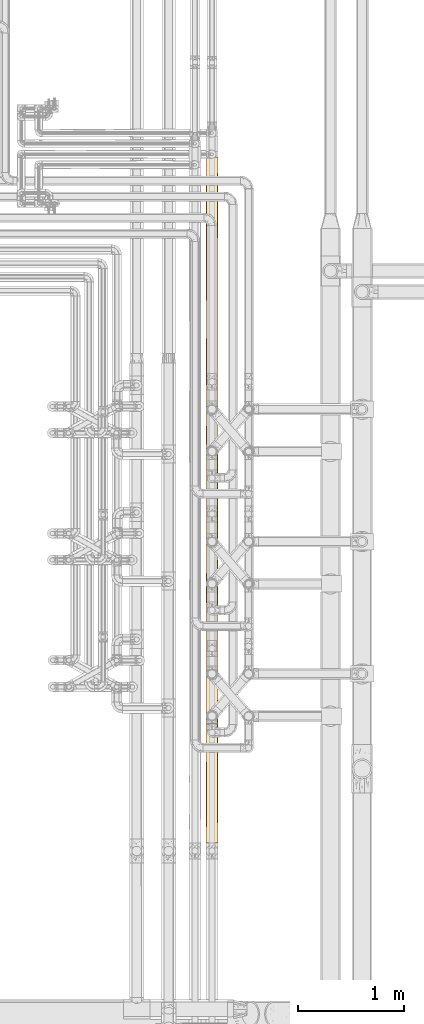
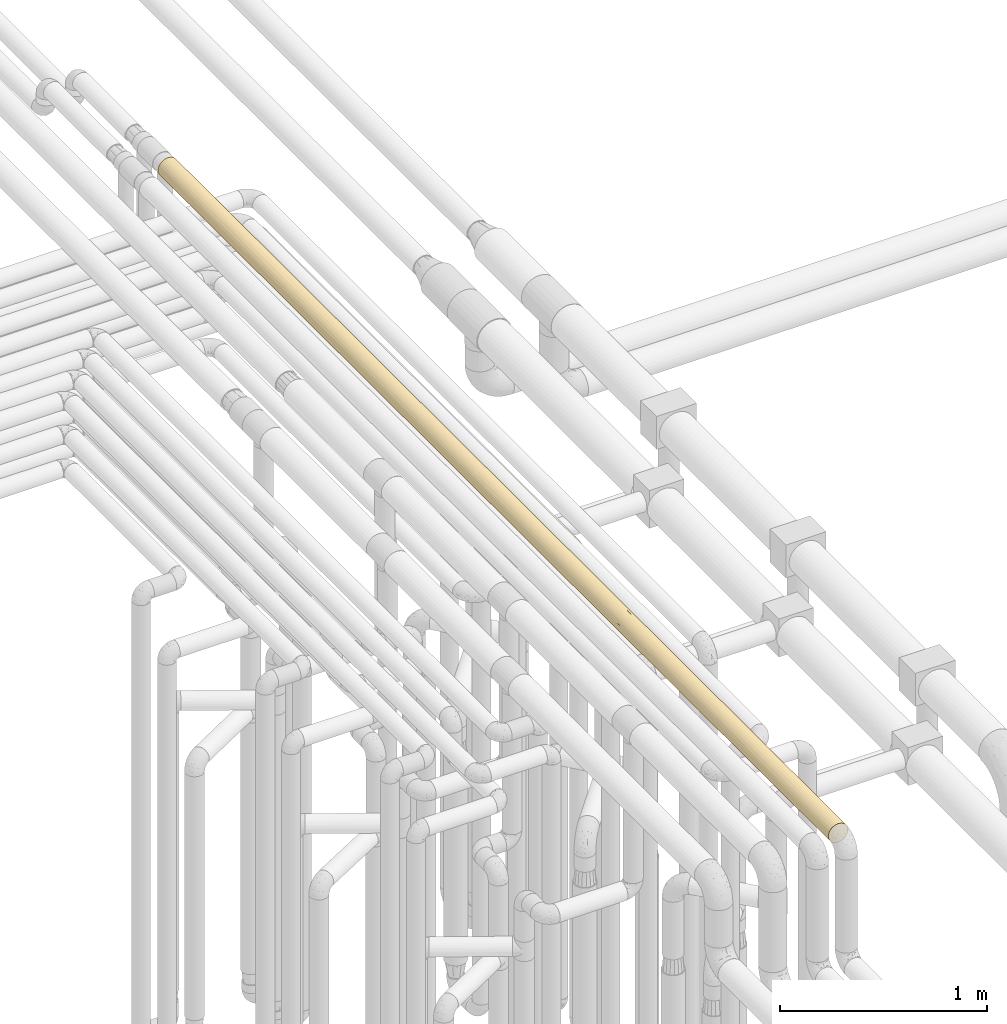
# One storey, part 37 of 827: 1 covering.
"""IFC2X3 building model written with IfcOpenShell, lengths in millimetres."""

from ifc_helpers import new_model, entity, si_unit, converted_unit, derived_unit, direction, frame, origin, place, context, subcontext, project, spatial, faceted_brep, element, save


model = new_model("IFC2X3")

# Units and contexts
model_context = context("Model", 3, precision=0.01, world=origin(), true_north=direction((6.12303176911189e-17, 1.0)))
body_context = subcontext(model_context, "Body", "Model", "MODEL_VIEW")
ifc_project = project(units=[si_unit("LENGTHUNIT", "METRE", prefix="MILLI"), si_unit("AREAUNIT", "SQUARE_METRE"), si_unit("VOLUMEUNIT", "CUBIC_METRE"), converted_unit("PLANEANGLEUNIT", "DEGREE", entity("IfcRatioMeasure", 0.0174532925199433), si_unit("PLANEANGLEUNIT", "RADIAN"), dimensions=[0, 0, 0, 0, 0, 0, 0]), si_unit("MASSUNIT", "GRAM", prefix="KILO"), derived_unit("MASSDENSITYUNIT", [(si_unit("MASSUNIT", "GRAM", prefix="KILO"), 1), (si_unit("LENGTHUNIT", "METRE"), -3)]), derived_unit("MOMENTOFINERTIAUNIT", [(si_unit("LENGTHUNIT", "METRE"), 4)]), si_unit("TIMEUNIT", "SECOND"), si_unit("FREQUENCYUNIT", "HERTZ"), si_unit("THERMODYNAMICTEMPERATUREUNIT", "DEGREE_CELSIUS"), derived_unit("THERMALTRANSMITTANCEUNIT", [(si_unit("MASSUNIT", "GRAM", prefix="KILO"), 1), (si_unit("THERMODYNAMICTEMPERATUREUNIT", "KELVIN"), -1), (si_unit("TIMEUNIT", "SECOND"), -3)]), derived_unit("VOLUMETRICFLOWRATEUNIT", [(si_unit("LENGTHUNIT", "METRE"), 3), (si_unit("TIMEUNIT", "SECOND"), -1)]), derived_unit("MASSFLOWRATEUNIT", [(si_unit("MASSUNIT", "GRAM", prefix="KILO"), 1), (si_unit("TIMEUNIT", "SECOND"), -1)]), derived_unit("ROTATIONALFREQUENCYUNIT", [(si_unit("TIMEUNIT", "SECOND"), -1)]), si_unit("ELECTRICCURRENTUNIT", "AMPERE"), si_unit("ELECTRICVOLTAGEUNIT", "VOLT"), si_unit("POWERUNIT", "WATT"), si_unit("FORCEUNIT", "NEWTON", prefix="KILO"), si_unit("ILLUMINANCEUNIT", "LUX"), si_unit("LUMINOUSFLUXUNIT", "LUMEN"), si_unit("LUMINOUSINTENSITYUNIT", "CANDELA"), derived_unit("USERDEFINED", [(si_unit("MASSUNIT", "GRAM", prefix="KILO"), -1), (si_unit("LENGTHUNIT", "METRE"), -2), (si_unit("TIMEUNIT", "SECOND"), 3), (si_unit("LUMINOUSFLUXUNIT", "LUMEN"), 1)]), derived_unit("LINEARVELOCITYUNIT", [(si_unit("LENGTHUNIT", "METRE"), 1), (si_unit("TIMEUNIT", "SECOND"), -1)]), si_unit("PRESSUREUNIT", "PASCAL"), derived_unit("USERDEFINED", [(si_unit("LENGTHUNIT", "METRE"), -2), (si_unit("MASSUNIT", "GRAM", prefix="KILO"), 1), (si_unit("TIMEUNIT", "SECOND"), -2)]), derived_unit("LINEARFORCEUNIT", [(si_unit("MASSUNIT", "GRAM", prefix="KILO"), 1), (si_unit("LENGTHUNIT", "METRE"), 1), (si_unit("TIMEUNIT", "SECOND"), -2), (si_unit("LENGTHUNIT", "METRE"), -1)]), derived_unit("PLANARFORCEUNIT", [(si_unit("MASSUNIT", "GRAM", prefix="KILO"), 1), (si_unit("LENGTHUNIT", "METRE"), 1), (si_unit("TIMEUNIT", "SECOND"), -2), (si_unit("LENGTHUNIT", "METRE"), -2)])], contexts=[model_context])

# Site, building, storey
site_placement = place(None, origin())
site = spatial("IfcSite", under=ifc_project, at=site_placement, CompositionType="ELEMENT")
building_placement = place(site_placement, origin())
building = spatial("IfcBuilding", under=site, at=building_placement, CompositionType="ELEMENT")
storey_placement = place(building_placement, frame((0.0, 0.0, 28200.0)))
storey = spatial("IfcBuildingStorey", under=building, at=storey_placement, Name="08", CompositionType="ELEMENT", Elevation=28200.0)

# Covering
covering_placement = place(storey_placement, frame((36573.05, 8883.39, 3493.4)))
element("IfcCovering", 1, at=covering_placement, inside=storey, Name=":ADSK_", ObjectType=":ADSK_", PredefinedType="INSULATION", context=body_context, shape_type="Brep", body=[
    faceted_brep([(29.1, 6478.71, 104.23), (42.36, 6478.71, 109.72), (56.6, 6478.71, 111.6), (70.83, 6478.71, 109.72), (84.1, 6478.71, 104.23), (95.49, 6478.71, 95.49), (104.23, 6478.71, 84.1), (109.72, 6478.71, 70.83), (111.6, 6478.71, 56.6), (110.51, 6478.71, 45.71), (107.3, 6478.71, 35.29), (102.09, 6478.71, 25.69), (95.09, 6478.71, 17.31), (18.1, 6478.71, 17.31), (11.1, 6478.71, 25.69), (5.89, 6478.71, 35.29), (2.68, 6478.71, 45.71), (1.6, 6478.71, 56.6), (3.47, 6478.71, 70.83), (8.96, 6478.71, 84.1), (17.7, 6478.71, 95.49), (29.1, 0.0, 104.23), (17.7, 0.0, 95.49), (8.96, 0.0, 84.1), (3.47, 0.0, 70.83), (1.6, 0.0, 56.6), (3.47, 0.0, 42.36), (8.96, 0.0, 29.1), (17.7, 0.0, 17.7), (29.1, 0.0, 8.96), (42.36, 0.0, 3.47), (56.6, 0.0, 1.6), (70.83, 0.0, 3.47), (84.1, 0.0, 8.96), (95.49, 0.0, 17.7), (104.23, 0.0, 29.1), (109.72, 0.0, 42.36), (111.6, 0.0, 56.6), (109.72, 0.0, 70.83), (104.23, 0.0, 84.1), (95.49, 0.0, 95.49), (84.1, 0.0, 104.23), (70.83, 0.0, 109.72), (56.6, 0.0, 111.6), (42.36, 0.0, 109.72), (107.41, 671.54, 35.55), (100.46, 853.03, 23.42), (106.98, 1112.54, 34.54), (96.95, 1745.06, 19.23), (103.58, 1846.43, 28.01), (105.57, 1545.04, 31.56), (100.23, 424.64, 23.11), (87.34, 665.83, 10.99), (96.09, 3932.19, 18.32), (82.23, 3799.7, 7.94), (86.05, 4279.11, 10.15), (72.0, 5396.7, 3.8), (69.58, 5700.46, 3.15), (81.02, 5554.54, 7.32), (107.41, 306.15, 35.55), (109.16, 6090.44, 40.42), (104.93, 6107.46, 30.36), (82.31, 6215.97, 7.98), (77.38, 6470.57, 5.68), (86.8, 6474.04, 10.63), (98.8, 6090.37, 21.33), (104.94, 5804.09, 30.36), (82.42, 5920.15, 8.03), (90.08, 352.85, 12.96), (109.83, 3477.09, 42.78), (103.49, 3531.29, 27.86), (106.38, 3832.84, 33.21), (110.08, 1395.56, 43.79), (111.6, 1035.81, 56.6), (110.44, 1081.94, 45.36), (110.58, 615.17, 46.05), (111.6, 517.9, 56.6), (110.78, 307.2, 47.18), (56.6, 517.9, 1.6), (66.22, 311.86, 2.44), (101.33, 5453.87, 24.6), (97.18, 5070.07, 19.48), (91.57, 5436.91, 14.14), (77.64, 239.04, 5.78), (72.44, 6133.11, 3.93), (90.71, 6071.31, 13.46), (95.46, 5761.8, 17.68), (56.6, 5949.81, 1.6), (56.6, 6467.71, 1.6), (67.19, 6468.43, 2.62), (110.13, 5678.88, 43.99), (87.04, 5040.36, 10.79), (105.83, 5067.13, 32.09), (110.03, 5279.22, 43.55), (110.43, 4965.89, 45.32), (111.6, 5960.81, 56.6), (77.64, 550.38, 5.78), (67.15, 623.46, 2.62), (111.6, 5442.9, 56.6), (98.4, 1285.53, 20.85), (108.78, 2947.42, 39.22), (111.6, 2655.48, 56.6), (110.78, 2509.52, 47.15), (82.27, 2312.64, 7.95), (90.65, 2601.46, 13.4), (94.69, 2229.68, 16.92), (56.6, 5431.9, 1.6), (71.83, 4624.83, 3.75), (56.6, 4914.0, 1.6), (75.23, 5099.69, 4.85), (109.0, 4115.16, 39.9), (110.48, 4377.83, 45.57), (111.6, 4115.16, 56.6), (92.51, 4720.7, 14.94), (98.87, 4418.49, 21.41), (107.12, 5487.12, 34.85), (56.6, 1035.81, 1.6), (74.42, 1082.57, 4.56), (74.3, 807.27, 4.52), (111.6, 4925.0, 56.6), (109.53, 4666.05, 41.68), (86.43, 1425.52, 10.39), (84.59, 1885.05, 9.25), (56.6, 4396.1, 1.6), (101.9, 4763.36, 25.42), (111.6, 4793.07, 56.6), (111.6, 4468.15, 56.6), (111.6, 4407.1, 56.6), (107.89, 2534.71, 36.74), (100.62, 2655.48, 23.62), (105.67, 4480.27, 31.75), (70.33, 2063.72, 3.34), (103.64, 4138.61, 28.1), (91.92, 3549.47, 14.44), (94.14, 3148.43, 16.4), (81.48, 3332.99, 7.55), (110.27, 3808.42, 44.61), (111.6, 3531.29, 56.6), (111.6, 5117.98, 56.6), (95.19, 2850.61, 17.41), (68.98, 3619.24, 3.01), (56.6, 3360.29, 1.6), (56.6, 3878.19, 1.6), (90.08, 978.81, 12.96), (72.66, 1603.91, 4.0), (56.6, 1357.98, 1.6), (100.68, 2093.51, 23.72), (105.99, 2136.7, 32.41), (103.3, 3129.82, 27.56), (109.79, 1826.92, 42.61), (110.23, 2179.76, 44.43), (111.6, 2071.61, 56.6), (102.78, 2375.07, 26.72), (69.9, 2459.5, 3.23), (67.8, 2773.82, 2.75), (78.62, 2828.42, 6.2), (69.26, 3247.93, 3.07), (111.6, 1553.71, 56.6), (56.6, 1680.14, 1.6), (56.6, 2002.31, 1.6), (56.6, 2324.48, 1.6), (111.6, 3239.36, 56.6), (111.6, 2363.55, 56.6), (87.27, 2963.64, 10.95), (56.6, 2842.39, 1.6), (71.0, 4140.38, 3.51), (56.6, 4137.14, 1.6), (82.48, 4736.23, 8.07), (111.6, 3107.42, 56.6), (111.6, 2947.42, 56.6), (111.6, 2589.52, 56.6), (111.6, 3823.23, 56.6), (111.6, 3625.32, 56.6), (111.6, 4143.23, 56.6), (111.6, 3366.37, 56.6), (12.96, 424.64, 23.11), (23.11, 352.85, 12.96), (13.85, 6070.66, 21.98), (21.91, 6089.0, 13.91), (8.26, 6220.38, 30.36), (23.11, 978.81, 12.96), (25.85, 665.83, 10.99), (12.73, 853.03, 23.42), (35.55, 239.04, 5.78), (40.73, 6081.99, 3.93), (44.29, 5674.02, 2.99), (30.72, 5796.14, 8.06), (29.4, 4212.82, 8.79), (31.06, 4539.06, 7.88), (39.59, 4329.49, 4.29), (35.81, 6470.57, 5.68), (30.84, 6093.21, 8.0), (26.39, 6474.04, 10.63), (5.78, 306.15, 35.55), (2.41, 307.2, 47.18), (2.62, 615.17, 46.05), (18.5, 2229.68, 16.92), (12.51, 2093.51, 23.72), (10.41, 2375.07, 26.72), (1.6, 517.9, 56.6), (18.15, 5755.78, 17.26), (8.26, 5920.94, 30.36), (18.24, 3982.03, 17.18), (21.59, 4415.83, 14.17), (10.9, 5091.39, 25.99), (7.32, 5393.34, 32.16), (14.39, 5428.81, 21.33), (46.97, 311.86, 2.44), (46.04, 623.46, 2.62), (26.76, 1425.52, 10.39), (14.79, 1285.53, 20.85), (32.4, 5060.76, 7.2), (43.56, 5279.28, 3.16), (45.19, 4961.02, 2.79), (3.11, 1395.56, 43.79), (1.6, 1035.81, 56.6), (1.6, 1553.71, 56.6), (1.6, 5960.81, 56.6), (4.03, 6138.19, 40.42), (46.0, 6468.43, 2.62), (19.66, 5056.75, 15.84), (25.03, 5439.8, 11.55), (3.2, 5698.25, 43.42), (3.24, 5369.44, 43.25), (6.21, 1112.54, 34.54), (7.62, 1545.04, 31.56), (38.89, 807.27, 4.52), (38.77, 1082.57, 4.56), (2.96, 2170.75, 44.4), (1.6, 2363.55, 56.6), (4.01, 2507.21, 40.47), (4.55, 3524.12, 38.81), (3.41, 3941.15, 42.58), (7.17, 3796.64, 32.46), (28.6, 1885.05, 9.25), (30.92, 2312.64, 7.95), (42.86, 2063.72, 3.34), (1.6, 5442.9, 56.6), (3.6, 4350.68, 41.89), (8.31, 4122.09, 30.27), (30.46, 3481.75, 8.2), (44.37, 3619.24, 2.97), (42.44, 3191.95, 3.45), (7.77, 4621.17, 31.27), (4.83, 5077.94, 38.0), (5.78, 671.54, 35.55), (35.55, 550.38, 5.78), (35.13, 5490.19, 5.96), (43.29, 2459.5, 3.23), (41.72, 4655.05, 3.64), (16.24, 1745.06, 19.23), (40.53, 1603.91, 4.0), (14.31, 4768.37, 21.43), (22.91, 4745.32, 13.12), (13.21, 4437.49, 22.79), (47.58, 4007.67, 2.34), (37.74, 4002.6, 4.93), (14.79, 3552.8, 20.86), (21.55, 3379.49, 14.2), (18.81, 3081.07, 16.63), (12.57, 2655.48, 23.62), (4.41, 2947.42, 39.22), (8.83, 3525.11, 29.33), (2.75, 1081.94, 45.36), (3.15, 1812.66, 43.61), (1.6, 2071.61, 56.6), (9.61, 1846.43, 28.01), (9.57, 3204.46, 28.07), (22.54, 2601.46, 13.4), (12.51, 2949.39, 23.7), (34.57, 2828.42, 6.2), (45.39, 2773.82, 2.75), (1.6, 2947.42, 56.6), (2.89, 3239.14, 44.71), (1.6, 2655.48, 56.6), (1.6, 4115.16, 56.6), (1.6, 4407.1, 56.6), (3.14, 4731.04, 43.67), (1.6, 3531.29, 56.6), (1.6, 3239.36, 56.6), (7.2, 2136.7, 32.41), (27.45, 3876.95, 9.95), (25.61, 2868.63, 11.16), (28.98, 3133.66, 9.03), (1.6, 4925.0, 56.6), (1.6, 3823.23, 56.6), (23.11, 424.64, 100.23), (12.96, 352.85, 90.08), (3.11, 5083.15, 69.4), (5.78, 6172.56, 77.64), (12.96, 6054.07, 90.08), (2.41, 6171.51, 66.01), (2.62, 5863.54, 67.14), (10.76, 1406.19, 87.0), (12.96, 978.81, 90.08), (20.85, 1285.53, 98.4), (35.55, 306.15, 107.41), (3.98, 3233.74, 72.61), (4.08, 2947.42, 72.94), (47.18, 307.2, 110.78), (46.05, 615.17, 110.58), (5.78, 239.04, 77.64), (34.54, 1112.54, 106.98), (31.56, 1545.04, 105.57), (23.11, 6125.86, 100.23), (26.79, 5052.14, 102.82), (23.11, 5499.9, 100.23), (14.79, 5193.18, 92.34), (4.12, 1583.76, 73.06), (9.89, 1843.99, 85.65), (4.03, 2010.45, 72.77), (10.99, 665.83, 87.34), (23.42, 853.03, 100.46), (56.6, 5960.81, 111.6), (46.97, 6166.85, 110.75), (46.04, 5855.25, 110.57), (35.55, 6239.67, 107.41), (12.73, 5625.68, 89.77), (25.85, 5812.88, 102.2), (56.6, 517.9, 111.6), (43.79, 1395.56, 110.08), (56.6, 1035.81, 111.6), (56.6, 1553.71, 111.6), (2.44, 311.86, 66.22), (2.62, 623.46, 67.15), (6.21, 5366.17, 78.65), (7.62, 4933.67, 81.63), (4.52, 808.09, 74.3), (4.57, 1084.08, 74.42), (38.89, 5671.46, 108.67), (38.77, 5396.17, 108.63), (28.82, 1892.81, 104.07), (19.65, 1723.33, 97.34), (45.63, 2842.94, 110.49), (56.6, 2589.52, 111.6), (56.6, 2655.49, 111.6), (56.6, 2947.42, 111.6), (56.6, 3107.42, 111.6), (30.69, 4138.73, 105.11), (33.39, 3689.17, 106.46), (43.28, 3975.87, 109.96), (3.15, 4666.05, 69.58), (9.3, 3572.89, 84.67), (11.86, 3868.74, 88.6), (6.13, 3834.12, 78.47), (42.99, 4412.48, 109.89), (35.55, 671.54, 107.41), (5.78, 550.38, 77.64), (5.78, 5807.17, 77.64), (35.55, 5928.33, 107.41), (5.87, 4459.68, 77.86), (40.56, 4873.68, 109.2), (28.66, 4591.43, 103.97), (10.92, 2379.57, 87.24), (12.11, 2103.58, 88.94), (17.65, 2256.74, 95.43), (45.36, 1081.94, 110.44), (43.61, 1812.66, 110.04), (56.6, 2071.61, 111.6), (17.84, 1985.61, 95.62), (25.07, 2241.08, 101.66), (15.99, 3612.55, 93.69), (21.94, 3851.92, 99.3), (37.75, 3168.89, 108.27), (31.97, 2805.26, 105.77), (19.98, 2833.65, 97.64), (25.06, 2510.54, 101.66), (7.7, 3152.65, 81.79), (2.53, 2509.52, 66.69), (16.91, 2556.6, 94.68), (5.59, 2417.18, 77.17), (33.46, 2220.45, 106.49), (44.19, 2137.7, 110.18), (43.62, 2462.76, 110.04), (10.24, 2848.3, 86.19), (4.51, 3516.16, 74.26), (13.38, 3319.01, 90.62), (2.74, 3841.04, 67.76), (4.08, 4115.16, 72.95), (23.29, 3447.7, 100.36), (56.6, 3625.33, 111.6), (44.67, 3644.69, 110.29), (8.59, 4136.75, 83.43), (19.5, 4234.02, 97.21), (17.49, 4773.64, 95.27), (2.75, 5396.77, 67.83), (11.32, 4419.66, 87.82), (56.6, 4793.07, 111.6), (56.6, 5117.98, 111.6), (56.6, 5442.9, 111.6), (56.6, 4143.23, 111.6), (56.6, 4407.1, 111.6), (56.6, 4468.15, 111.6), (20.63, 4515.43, 98.21), (2.66, 4370.89, 67.34), (56.6, 3823.23, 111.6), (56.6, 4115.16, 111.6), (26.53, 3112.4, 102.65), (47.43, 3236.9, 110.83), (56.6, 2363.55, 111.6), (56.6, 3366.37, 111.6), (56.6, 3531.29, 111.6), (56.6, 3239.36, 111.6), (34.0, 2505.36, 106.74), (56.6, 4925.0, 111.6), (100.23, 424.64, 90.08), (90.08, 352.85, 100.23), (69.4, 5083.15, 110.08), (77.64, 6172.56, 107.41), (90.08, 6054.07, 100.23), (66.01, 6171.51, 110.78), (67.14, 5863.54, 110.58), (87.0, 1406.19, 102.43), (90.08, 978.81, 100.23), (98.4, 1285.53, 92.34), (107.41, 306.15, 77.64), (72.94, 2947.42, 109.11), (66.69, 2509.52, 110.66), (110.78, 307.2, 66.01), (110.58, 615.17, 67.14), (77.64, 239.04, 107.41), (106.98, 1112.54, 78.65), (105.57, 1545.04, 81.63), (100.23, 6125.86, 90.08), (102.82, 5052.14, 86.4), (100.23, 5499.9, 90.08), (92.34, 5193.18, 98.4), (73.06, 1583.76, 109.07), (85.65, 1843.99, 103.3), (72.77, 2010.45, 109.16), (87.34, 665.83, 102.2), (100.46, 853.03, 89.77), (110.75, 6166.85, 66.22), (110.57, 5855.25, 67.15), (107.41, 6239.67, 77.64), (89.77, 5625.68, 100.46), (102.2, 5812.88, 87.34), (110.08, 1395.56, 69.4), (66.22, 311.86, 110.75), (67.15, 623.46, 110.57), (78.65, 5366.17, 106.98), (81.63, 4933.67, 105.57), (74.3, 808.09, 108.67), (74.42, 1084.08, 108.63), (108.67, 5671.46, 74.3), (108.63, 5396.17, 74.42), (104.07, 1892.81, 84.37), (97.34, 1723.33, 93.54), (110.49, 2842.94, 67.56), (105.11, 4138.73, 82.5), (106.46, 3689.17, 79.8), (109.96, 3975.87, 69.91), (69.58, 4666.05, 110.04), (84.67, 3572.89, 103.89), (88.6, 3868.74, 101.33), (78.47, 3834.12, 107.06), (109.89, 4412.48, 70.2), (107.41, 671.54, 77.64), (77.64, 550.38, 107.41), (77.64, 5807.17, 107.41), (107.41, 5928.33, 77.64), (77.86, 4459.68, 107.32), (109.2, 4873.68, 72.63), (103.97, 4591.43, 84.53), (87.24, 2379.57, 102.27), (88.94, 2103.58, 101.08), (95.43, 2256.74, 95.55), (110.44, 1081.94, 67.83), (110.04, 1812.66, 69.58), (95.62, 1985.61, 95.35), (101.66, 2241.08, 88.12), (93.69, 3612.55, 97.2), (99.3, 3851.92, 91.25), (108.27, 3168.89, 75.44), (105.77, 2805.26, 81.22), (97.64, 2833.65, 93.21), (101.66, 2510.54, 88.13), (81.79, 3152.65, 105.49), (72.61, 3233.74, 109.21), (94.68, 2556.6, 96.28), (77.17, 2417.18, 107.6), (106.49, 2220.45, 79.73), (110.18, 2137.7, 69.0), (110.04, 2462.76, 69.57), (86.19, 2848.3, 102.95), (74.26, 3516.16, 108.68), (90.62, 3319.01, 99.81), (67.76, 3841.04, 110.45), (100.36, 3447.7, 89.9), (110.29, 3644.69, 68.52), (83.43, 4136.75, 104.6), (72.95, 4115.16, 109.11), (97.21, 4234.02, 93.69), (95.27, 4773.64, 95.71), (67.83, 5396.77, 110.44), (87.82, 4419.66, 101.87), (98.21, 4515.43, 92.56), (67.34, 4370.89, 110.53), (102.65, 3112.4, 86.66), (110.83, 3236.9, 65.76), (106.74, 2505.36, 79.19)], [[[0, 1, 2, 3, 4, 5, 6, 7, 8, 9, 10, 11, 12, 13, 14, 15, 16, 17, 18, 19, 20]], [[21, 22, 23, 24, 25, 26, 27, 28, 29, 30, 31, 32, 33, 34, 35, 36, 37, 38, 39, 40, 41, 42, 43, 44]], [[45, 46, 47]], [[48, 49, 50]], [[46, 51, 52]], [[53, 54, 55]], [[56, 57, 58]], [[59, 36, 35]], [[60, 61, 10]], [[51, 45, 59]], [[62, 63, 64]], [[65, 61, 66]], [[58, 57, 67]], [[51, 34, 68]], [[69, 70, 71]], [[72, 73, 74]], [[75, 76, 77]], [[31, 78, 79]], [[80, 81, 82]], [[60, 66, 61]], [[32, 83, 33]], [[63, 62, 84]], [[67, 85, 86]], [[87, 88, 89]], [[65, 12, 11]], [[66, 60, 90]], [[82, 81, 91]], [[92, 93, 94]], [[10, 9, 60]], [[47, 50, 72]], [[85, 12, 65]], [[77, 36, 59]], [[84, 57, 87]], [[63, 84, 89]], [[9, 8, 95]], [[51, 35, 34]], [[45, 51, 46]], [[96, 83, 79]], [[79, 97, 96]], [[82, 58, 86]], [[85, 67, 62]], [[9, 95, 60]], [[90, 95, 98]], [[57, 84, 67]], [[87, 89, 84]], [[50, 47, 99]], [[100, 101, 102]], [[48, 50, 99]], [[103, 104, 105]], [[67, 86, 58]], [[106, 87, 57]], [[82, 86, 80]], [[107, 108, 109]], [[110, 111, 112]], [[55, 113, 114]], [[34, 33, 68]], [[36, 77, 37]], [[68, 52, 51]], [[90, 93, 115]], [[116, 117, 118]], [[119, 120, 94]], [[48, 121, 122]], [[108, 107, 123]], [[95, 90, 60]], [[90, 98, 93]], [[83, 68, 33]], [[52, 68, 96]], [[64, 12, 85]], [[84, 62, 67]], [[85, 62, 64]], [[85, 65, 86]], [[65, 66, 86]], [[80, 86, 66]], [[115, 66, 90]], [[81, 80, 92]], [[92, 124, 81]], [[81, 124, 113]], [[120, 119, 125, 126, 127]], [[128, 129, 100]], [[120, 130, 124]], [[127, 111, 120]], [[103, 122, 131]], [[132, 71, 53]], [[133, 134, 135]], [[136, 137, 69]], [[124, 130, 114]], [[93, 98, 138, 119]], [[115, 92, 80]], [[129, 104, 139]], [[140, 141, 142]], [[51, 59, 35]], [[75, 77, 59]], [[99, 46, 143]], [[46, 99, 47]], [[121, 99, 143]], [[99, 121, 48]], [[143, 117, 121]], [[121, 144, 122]], [[143, 52, 118]], [[122, 144, 131]], [[117, 145, 144]], [[122, 105, 48]], [[146, 147, 49]], [[148, 69, 100]], [[117, 144, 121]], [[103, 105, 122]], [[149, 150, 151]], [[146, 152, 147]], [[153, 154, 155]], [[140, 135, 156]], [[157, 72, 149]], [[74, 75, 45]], [[50, 149, 72]], [[47, 72, 74]], [[131, 158, 159, 160]], [[161, 100, 69]], [[131, 153, 103]], [[150, 102, 162]], [[139, 148, 129]], [[153, 131, 160]], [[105, 104, 129]], [[103, 155, 104]], [[134, 70, 148]], [[163, 134, 139]], [[135, 140, 54]], [[75, 59, 45]], [[37, 77, 76]], [[74, 45, 47]], [[73, 76, 75]], [[141, 156, 164]], [[155, 103, 153]], [[160, 164, 154]], [[49, 149, 50]], [[73, 72, 157]], [[150, 149, 147]], [[157, 149, 151]], [[120, 124, 92]], [[113, 124, 114]], [[114, 53, 55]], [[91, 81, 113]], [[165, 55, 54]], [[55, 165, 107]], [[132, 114, 130]], [[133, 70, 134]], [[165, 142, 166, 123]], [[165, 54, 140]], [[165, 123, 107]], [[108, 106, 56]], [[55, 107, 167]], [[91, 167, 109]], [[167, 91, 113]], [[91, 109, 58]], [[111, 130, 120]], [[132, 130, 110]], [[71, 132, 110]], [[53, 114, 132]], [[92, 94, 120]], [[53, 71, 70]], [[136, 71, 110]], [[69, 148, 70]], [[69, 71, 136]], [[55, 167, 113]], [[109, 167, 107]], [[91, 58, 82]], [[56, 58, 109]], [[108, 56, 109]], [[106, 57, 56]], [[165, 140, 142]], [[133, 135, 54]], [[163, 135, 134]], [[140, 156, 141]], [[54, 53, 133]], [[70, 133, 53]], [[135, 155, 156]], [[156, 155, 154]], [[128, 150, 147]], [[102, 150, 128]], [[128, 147, 152]], [[100, 161, 168, 169, 101]], [[102, 101, 170, 162]], [[162, 151, 150]], [[100, 102, 128]], [[92, 115, 93]], [[66, 115, 80]], [[145, 117, 116]], [[145, 158, 144]], [[75, 74, 73]], [[79, 83, 32]], [[68, 83, 96]], [[31, 79, 32]], [[79, 78, 97]], [[116, 97, 78]], [[118, 96, 97]], [[116, 118, 97]], [[143, 118, 117]], [[65, 11, 61]], [[10, 61, 11]], [[118, 52, 96]], [[46, 52, 143]], [[171, 172, 137, 136, 112]], [[130, 111, 110]], [[111, 127, 173, 112]], [[136, 110, 112]], [[93, 119, 94]], [[146, 48, 105]], [[149, 49, 147]], [[48, 146, 49]], [[152, 105, 129]], [[105, 152, 146]], [[128, 152, 129]], [[158, 131, 144]], [[129, 148, 100]], [[163, 104, 155]], [[148, 139, 134]], [[104, 163, 139]], [[135, 163, 155]], [[160, 154, 153]], [[156, 154, 164]], [[69, 137, 174, 161]], [[175, 176, 28]], [[177, 13, 178]], [[29, 28, 176]], [[15, 14, 179]], [[180, 181, 182]], [[183, 30, 29]], [[184, 185, 186]], [[187, 188, 189]], [[190, 191, 192]], [[178, 191, 186]], [[27, 26, 193]], [[193, 194, 195]], [[196, 197, 198]], [[25, 199, 194]], [[177, 200, 201]], [[202, 203, 187]], [[204, 205, 206]], [[186, 191, 184]], [[78, 207, 208]], [[178, 13, 192]], [[209, 180, 210]], [[211, 212, 213]], [[214, 215, 216]], [[16, 217, 17]], [[15, 179, 218]], [[27, 193, 175]], [[190, 219, 184]], [[220, 204, 206]], [[221, 220, 206]], [[222, 205, 223]], [[222, 217, 218]], [[15, 218, 16]], [[219, 88, 87]], [[224, 225, 210]], [[27, 175, 28]], [[226, 180, 227]], [[30, 183, 207]], [[200, 206, 201]], [[177, 201, 179]], [[219, 87, 184]], [[185, 87, 106]], [[228, 229, 230]], [[180, 182, 210]], [[231, 232, 233]], [[234, 235, 236]], [[222, 218, 201]], [[217, 16, 218]], [[205, 201, 206]], [[217, 222, 237]], [[206, 200, 221]], [[238, 239, 232]], [[240, 241, 242]], [[204, 243, 244]], [[182, 175, 245]], [[193, 195, 245]], [[176, 181, 246]], [[185, 212, 247]], [[235, 248, 236]], [[30, 207, 31]], [[108, 249, 213]], [[209, 250, 234]], [[251, 209, 234]], [[87, 185, 184]], [[185, 106, 212]], [[175, 182, 181]], [[183, 176, 246]], [[14, 13, 177]], [[218, 179, 201]], [[177, 179, 14]], [[177, 178, 200]], [[178, 186, 200]], [[221, 200, 186]], [[247, 186, 185]], [[220, 221, 211]], [[203, 252, 253]], [[243, 252, 254]], [[108, 123, 249]], [[123, 166, 142, 255]], [[253, 188, 203]], [[256, 255, 241]], [[257, 258, 259]], [[260, 230, 261]], [[231, 233, 262]], [[108, 212, 106]], [[247, 211, 221]], [[194, 193, 26]], [[175, 193, 245]], [[224, 182, 245]], [[182, 224, 210]], [[263, 245, 195]], [[224, 214, 225]], [[250, 210, 225]], [[264, 216, 265]], [[210, 250, 209]], [[266, 250, 225]], [[196, 234, 250]], [[264, 225, 214]], [[257, 259, 267]], [[250, 266, 197]], [[230, 260, 198]], [[268, 235, 196]], [[260, 269, 268]], [[270, 271, 248]], [[251, 236, 158]], [[227, 180, 209]], [[227, 209, 251]], [[227, 251, 145]], [[116, 78, 208]], [[236, 251, 234]], [[116, 227, 145]], [[234, 196, 235]], [[236, 160, 159, 158]], [[261, 272, 273]], [[261, 230, 274]], [[232, 275, 238]], [[254, 202, 239]], [[238, 275, 276]], [[277, 244, 243]], [[278, 273, 272, 279]], [[228, 264, 265]], [[266, 264, 280]], [[268, 196, 260]], [[236, 248, 160]], [[267, 269, 261]], [[270, 235, 268]], [[281, 257, 202]], [[282, 283, 270]], [[123, 255, 189]], [[258, 283, 259]], [[25, 194, 26]], [[194, 199, 195]], [[199, 215, 195]], [[195, 215, 263]], [[235, 270, 248]], [[263, 214, 224]], [[242, 164, 271]], [[160, 248, 271]], [[264, 214, 216]], [[204, 252, 243]], [[205, 204, 244]], [[204, 220, 252]], [[223, 284, 237]], [[223, 205, 244]], [[201, 205, 222]], [[253, 252, 220]], [[254, 252, 203]], [[220, 211, 253]], [[188, 211, 249]], [[211, 188, 253]], [[189, 188, 249]], [[123, 189, 249]], [[187, 189, 256]], [[242, 241, 141]], [[241, 142, 141]], [[240, 256, 241]], [[164, 242, 141]], [[242, 270, 283]], [[281, 202, 187]], [[203, 188, 187]], [[187, 256, 281]], [[202, 257, 233]], [[256, 240, 281]], [[281, 240, 258]], [[241, 255, 142]], [[189, 255, 256]], [[202, 254, 203]], [[239, 243, 254]], [[223, 244, 284]], [[237, 222, 223]], [[269, 267, 259]], [[267, 261, 273]], [[238, 243, 239]], [[277, 243, 238]], [[277, 276, 284]], [[233, 232, 239]], [[285, 232, 231]], [[276, 277, 238]], [[284, 244, 277]], [[211, 247, 212]], [[186, 247, 221]], [[202, 233, 239]], [[262, 233, 257]], [[257, 267, 262]], [[267, 231, 262]], [[251, 158, 145]], [[263, 224, 245]], [[215, 214, 263]], [[176, 183, 29]], [[246, 208, 207]], [[246, 207, 183]], [[31, 207, 78]], [[246, 226, 208]], [[208, 226, 116]], [[226, 246, 181]], [[116, 226, 227]], [[192, 191, 178]], [[190, 184, 191]], [[181, 176, 175]], [[226, 181, 180]], [[211, 213, 249]], [[212, 108, 213]], [[264, 266, 225]], [[197, 266, 280]], [[198, 197, 280]], [[250, 197, 196]], [[198, 280, 230]], [[196, 198, 260]], [[228, 230, 280]], [[261, 274, 272]], [[264, 228, 280]], [[229, 274, 230]], [[228, 265, 229]], [[278, 285, 231]], [[267, 273, 231]], [[273, 278, 231]], [[281, 258, 257]], [[283, 258, 240]], [[242, 283, 240]], [[270, 268, 282]], [[268, 259, 282]], [[259, 283, 282]], [[242, 271, 270]], [[160, 271, 164]], [[268, 269, 259]], [[261, 269, 260]], [[232, 285, 275]], [[286, 287, 22]], [[288, 237, 284]], [[19, 289, 290]], [[289, 291, 292]], [[293, 294, 295]], [[22, 287, 23]], [[296, 21, 44]], [[297, 272, 298]], [[296, 299, 300]], [[19, 18, 289]], [[301, 24, 23]], [[302, 303, 295]], [[0, 20, 304]], [[305, 306, 307]], [[17, 217, 291]], [[290, 304, 20]], [[308, 309, 310]], [[311, 312, 294]], [[313, 314, 315]], [[316, 1, 0]], [[317, 306, 318]], [[308, 310, 216]], [[43, 319, 299]], [[21, 296, 286]], [[320, 321, 322]], [[199, 323, 324]], [[21, 286, 22]], [[325, 326, 307]], [[19, 290, 20]], [[327, 294, 328]], [[24, 301, 323]], [[329, 306, 330]], [[1, 316, 314]], [[331, 332, 303]], [[312, 295, 294]], [[333, 334, 335, 336, 337]], [[338, 339, 340]], [[341, 326, 288]], [[306, 317, 307]], [[342, 343, 344]], [[340, 345, 338]], [[312, 286, 346]], [[296, 300, 346]], [[287, 311, 347]], [[317, 290, 348]], [[289, 292, 348]], [[304, 318, 349]], [[341, 350, 326]], [[24, 323, 25]], [[1, 314, 2]], [[351, 305, 352]], [[286, 312, 311]], [[301, 287, 347]], [[290, 289, 348]], [[290, 317, 318]], [[316, 304, 349]], [[286, 296, 346]], [[309, 293, 332]], [[353, 354, 355]], [[299, 296, 44]], [[291, 289, 18]], [[302, 312, 346]], [[312, 302, 295]], [[356, 346, 300]], [[302, 320, 303]], [[332, 295, 303]], [[357, 322, 358]], [[295, 332, 293]], [[320, 357, 303]], [[359, 331, 360]], [[361, 362, 343]], [[355, 354, 359]], [[363, 364, 333]], [[365, 366, 364]], [[367, 297, 298]], [[274, 368, 298]], [[369, 355, 366]], [[310, 370, 368]], [[309, 308, 293]], [[328, 294, 293]], [[328, 293, 308]], [[328, 216, 215]], [[215, 199, 324]], [[310, 309, 354]], [[328, 308, 216]], [[371, 372, 373]], [[331, 357, 371]], [[370, 353, 374]], [[367, 342, 375]], [[374, 376, 367]], [[374, 367, 298]], [[275, 377, 378]], [[375, 278, 297]], [[363, 339, 379]], [[339, 362, 379]], [[380, 340, 381]], [[361, 342, 376]], [[344, 382, 378]], [[343, 362, 383]], [[384, 352, 305]], [[325, 317, 348]], [[317, 325, 307]], [[385, 348, 292]], [[325, 288, 326]], [[384, 326, 386]], [[341, 284, 276]], [[307, 384, 305]], [[351, 345, 387]], [[330, 306, 305]], [[330, 305, 351]], [[330, 351, 388]], [[389, 313, 315]], [[345, 351, 352]], [[389, 330, 388]], [[345, 352, 338]], [[345, 390, 391, 392, 387]], [[352, 384, 393]], [[362, 339, 338]], [[276, 394, 341]], [[341, 394, 350]], [[326, 384, 307]], [[393, 386, 383]], [[43, 299, 44]], [[299, 319, 300]], [[17, 291, 18]], [[291, 217, 292]], [[368, 274, 229]], [[216, 310, 229, 265]], [[319, 321, 300]], [[300, 321, 356]], [[217, 237, 292]], [[292, 237, 385]], [[356, 320, 302]], [[357, 320, 322]], [[385, 288, 325]], [[341, 288, 284]], [[340, 380, 395, 396, 390]], [[383, 362, 338]], [[343, 342, 361]], [[365, 397, 376]], [[398, 381, 363]], [[364, 363, 397]], [[373, 358, 399, 334]], [[393, 338, 352]], [[333, 337, 398]], [[383, 386, 382]], [[340, 339, 381]], [[345, 340, 390]], [[339, 363, 381]], [[381, 400, 401, 380]], [[381, 398, 400]], [[398, 337, 402, 400]], [[398, 363, 333]], [[379, 397, 363]], [[373, 334, 333]], [[365, 369, 366]], [[360, 403, 366]], [[403, 333, 364]], [[371, 357, 372]], [[355, 360, 366]], [[403, 371, 373]], [[376, 397, 379]], [[365, 364, 397]], [[357, 358, 372]], [[358, 373, 372]], [[357, 331, 303]], [[331, 371, 360]], [[374, 369, 365]], [[353, 355, 369]], [[376, 374, 365]], [[370, 374, 298]], [[374, 353, 369]], [[370, 310, 354]], [[354, 353, 370]], [[359, 309, 332]], [[309, 359, 354]], [[331, 359, 332]], [[351, 387, 404, 388]], [[310, 368, 229]], [[298, 368, 370]], [[356, 302, 346]], [[321, 320, 356]], [[385, 325, 348]], [[237, 288, 385]], [[342, 367, 376]], [[297, 367, 375]], [[377, 278, 375]], [[344, 377, 375]], [[287, 301, 23]], [[347, 324, 323]], [[347, 323, 301]], [[25, 323, 199]], [[347, 327, 324]], [[324, 327, 215]], [[327, 347, 311]], [[215, 327, 328]], [[304, 316, 0]], [[349, 315, 314]], [[349, 314, 316]], [[2, 314, 313]], [[349, 329, 315]], [[315, 329, 389]], [[329, 349, 318]], [[389, 329, 330]], [[311, 287, 286]], [[327, 311, 294]], [[318, 304, 290]], [[329, 318, 306]], [[272, 297, 278, 279]], [[272, 274, 298]], [[343, 382, 344]], [[377, 344, 378]], [[375, 342, 344]], [[376, 379, 361]], [[362, 361, 379]], [[394, 275, 378]], [[377, 275, 285, 278]], [[383, 382, 343]], [[382, 386, 350]], [[275, 394, 276]], [[378, 382, 350]], [[350, 394, 378]], [[326, 350, 386]], [[386, 393, 384]], [[338, 393, 383]], [[360, 355, 359]], [[403, 360, 371]], [[333, 403, 373]], [[364, 366, 403]], [[405, 406, 40]], [[407, 389, 388, 404]], [[4, 408, 409]], [[408, 410, 411]], [[412, 413, 414]], [[40, 406, 41]], [[415, 39, 38]], [[416, 335, 417]], [[415, 418, 419]], [[4, 3, 408]], [[420, 42, 41]], [[421, 422, 414]], [[6, 5, 423]], [[424, 425, 426]], [[2, 313, 410]], [[409, 423, 5]], [[427, 428, 429]], [[430, 431, 413]], [[95, 432, 433]], [[434, 7, 6]], [[435, 425, 436]], [[427, 429, 322]], [[37, 76, 418]], [[39, 415, 405]], [[437, 73, 157]], [[319, 438, 439]], [[39, 405, 40]], [[440, 441, 426]], [[4, 409, 5]], [[442, 413, 443]], [[42, 420, 438]], [[444, 425, 445]], [[7, 434, 432]], [[446, 447, 422]], [[431, 414, 413]], [[448, 170, 101, 169, 168]], [[449, 450, 451]], [[452, 441, 407]], [[425, 435, 426]], [[453, 454, 455]], [[451, 456, 449]], [[431, 405, 457]], [[415, 419, 457]], [[406, 430, 458]], [[435, 409, 459]], [[408, 411, 459]], [[423, 436, 460]], [[452, 461, 441]], [[42, 438, 43]], [[7, 432, 8]], [[462, 424, 463]], [[405, 431, 430]], [[420, 406, 458]], [[409, 408, 459]], [[409, 435, 436]], [[434, 423, 460]], [[405, 415, 457]], [[428, 412, 447]], [[464, 465, 466]], [[418, 415, 38]], [[410, 408, 3]], [[421, 431, 457]], [[431, 421, 414]], [[467, 457, 419]], [[421, 437, 422]], [[447, 414, 422]], [[468, 157, 151]], [[414, 447, 412]], [[437, 468, 422]], [[469, 446, 470]], [[471, 472, 454]], [[466, 465, 469]], [[473, 474, 448]], [[475, 476, 474]], [[477, 478, 416]], [[478, 401, 400, 402, 337, 336]], [[479, 466, 476]], [[429, 480, 417]], [[428, 427, 412]], [[443, 413, 412]], [[443, 412, 427]], [[443, 322, 321]], [[321, 319, 439]], [[429, 428, 465]], [[443, 427, 322]], [[481, 482, 483]], [[446, 468, 481]], [[480, 464, 484]], [[477, 453, 485]], [[484, 486, 477]], [[484, 477, 416]], [[396, 395, 380, 401, 487]], [[485, 401, 478]], [[473, 450, 488]], [[450, 472, 488]], [[172, 451, 489]], [[471, 453, 486]], [[455, 490, 491]], [[454, 472, 492]], [[493, 463, 424]], [[440, 435, 459]], [[435, 440, 426]], [[494, 459, 411]], [[440, 407, 441]], [[493, 441, 495]], [[452, 404, 387, 392, 391]], [[426, 493, 424]], [[462, 456, 125]], [[445, 425, 424]], [[445, 424, 462]], [[445, 462, 138]], [[98, 95, 433]], [[456, 462, 463]], [[98, 445, 138]], [[456, 463, 449]], [[456, 173, 127, 126, 125]], [[463, 493, 496]], [[472, 450, 449]], [[391, 497, 452]], [[452, 497, 461]], [[441, 493, 426]], [[496, 495, 492]], [[37, 418, 38]], [[418, 76, 419]], [[2, 410, 3]], [[410, 313, 411]], [[417, 335, 334, 399]], [[322, 429, 399, 358]], [[76, 73, 419]], [[419, 73, 467]], [[313, 389, 411]], [[411, 389, 494]], [[467, 437, 421]], [[468, 437, 157]], [[494, 407, 440]], [[452, 407, 404]], [[451, 172, 171, 112, 173]], [[492, 472, 449]], [[454, 453, 471]], [[475, 498, 486]], [[499, 489, 473]], [[474, 473, 498]], [[483, 151, 162, 170]], [[496, 449, 463]], [[448, 168, 499]], [[492, 495, 490]], [[451, 450, 489]], [[456, 451, 173]], [[450, 473, 489]], [[489, 174, 137, 172]], [[489, 499, 174]], [[499, 168, 161, 174]], [[499, 473, 448]], [[488, 498, 473]], [[483, 170, 448]], [[475, 479, 476]], [[470, 500, 476]], [[500, 448, 474]], [[481, 468, 482]], [[466, 470, 476]], [[500, 481, 483]], [[486, 498, 488]], [[475, 474, 498]], [[468, 151, 482]], [[151, 483, 482]], [[468, 446, 422]], [[446, 481, 470]], [[484, 479, 475]], [[464, 466, 479]], [[486, 484, 475]], [[480, 484, 416]], [[484, 464, 479]], [[480, 429, 465]], [[465, 464, 480]], [[469, 428, 447]], [[428, 469, 465]], [[446, 469, 447]], [[462, 125, 119, 138]], [[429, 417, 399]], [[416, 417, 480]], [[467, 421, 457]], [[73, 437, 467]], [[494, 440, 459]], [[389, 407, 494]], [[453, 477, 486]], [[478, 477, 485]], [[487, 401, 485]], [[336, 335, 416]], [[406, 420, 41]], [[458, 439, 438]], [[458, 438, 420]], [[43, 438, 319]], [[458, 442, 439]], [[439, 442, 321]], [[442, 458, 430]], [[321, 442, 443]], [[423, 434, 6]], [[460, 433, 432]], [[460, 432, 434]], [[8, 432, 95]], [[460, 444, 433]], [[433, 444, 98]], [[444, 460, 436]], [[98, 444, 445]], [[430, 406, 405]], [[442, 430, 413]], [[436, 423, 409]], [[444, 436, 425]], [[478, 336, 416]], [[455, 487, 485]], [[454, 490, 455]], [[487, 455, 491]], [[485, 453, 455]], [[486, 488, 471]], [[472, 471, 488]], [[487, 491, 396]], [[497, 396, 491]], [[492, 490, 454]], [[490, 495, 461]], [[497, 391, 390, 396]], [[491, 490, 461]], [[461, 497, 491]], [[441, 461, 495]], [[495, 496, 493]], [[449, 496, 492]], [[470, 466, 469]], [[500, 470, 481]], [[448, 500, 483]], [[474, 476, 500]], [[64, 63, 89, 88, 219, 190, 192, 13, 12]]]),
])

save(model, "model.ifc")
